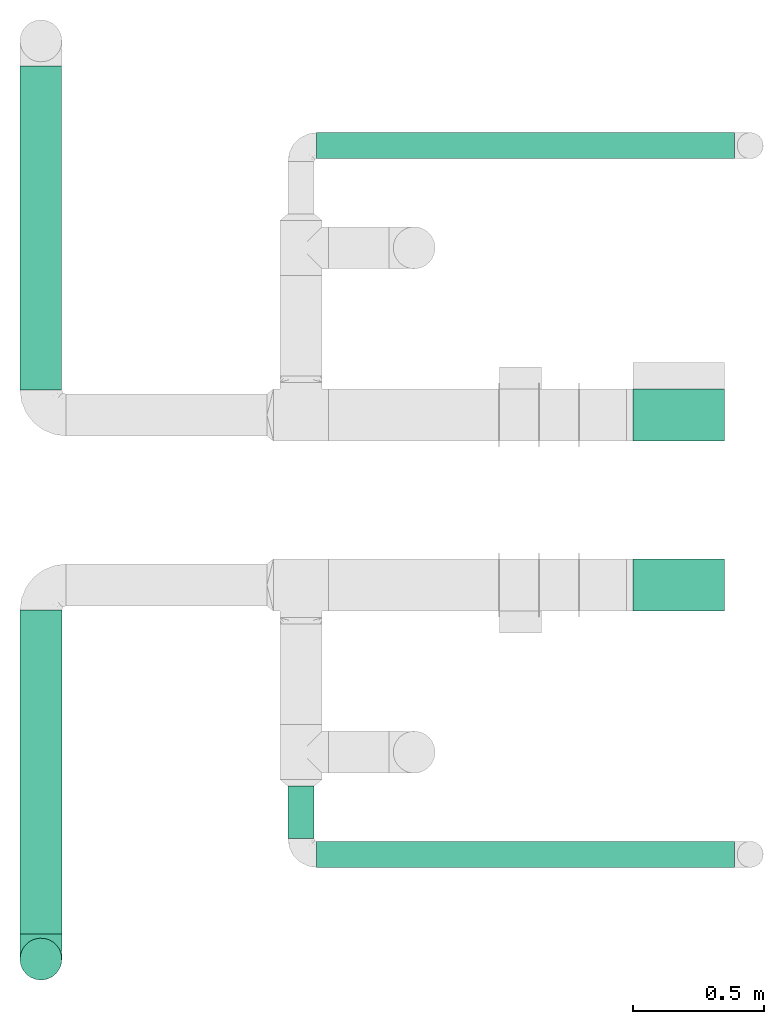
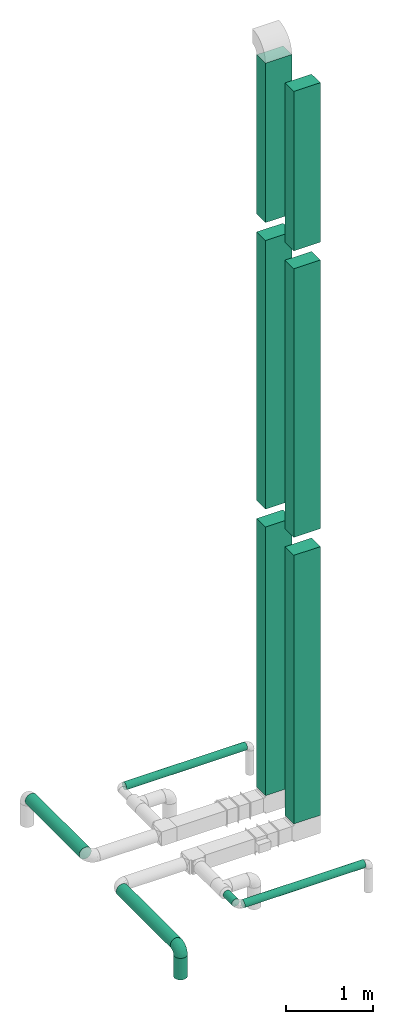
# One storey, part 1 of 12: 12 flow segments, 1 flow fitting.
"""IFC2X3 building model written with IfcOpenShell, lengths in millimetres."""

import ifcopenshell
import ifcopenshell.guid

model = None  # the IFC model being written
_history = None  # IfcOwnerHistory: only IFC2X3 demands one
_inside = {}  # id of a spatial element -> (the spatial element, [elements in it])
_under = {}  # id of a project, library or spatial element -> (it, [spatial elements below it])
_declared = {}  # id of a project -> (the project, [libraries it declares])
_typed = {}  # id of a type object -> (the type object, [elements of that type])
_made_of = {}  # id of a material, layer set ... -> (it, [elements and type objects made of it])


def new_model(schema):
    """Start an empty IFC model of exactly this schema.

    Asked for "IFC4X3", IfcOpenShell would pick the latest addendum, in which some entities
    have other attributes; the version numbers below select the first issue.
    IFC2X3 requires an IfcOwnerHistory on every rooted entity: one is made here for all.
    """
    global model, _history
    if schema == "IFC4X3":
        model = ifcopenshell.file(schema_version=(4, 3, 0, 0))
    else:
        model = ifcopenshell.file(schema=schema)
    _inside.clear()
    _under.clear()
    _declared.clear()
    _typed.clear()
    _made_of.clear()
    _history = None
    if model.schema == "IFC2X3":
        org = make("IfcOrganization", Name="unknown")
        user = make(
            "IfcPersonAndOrganization",
            ThePerson=make("IfcPerson", FamilyName="unknown"),
            TheOrganization=org,
        )
        app = make(
            "IfcApplication",
            ApplicationDeveloper=org,
            Version="unknown",
            ApplicationFullName="unknown",
            ApplicationIdentifier="unknown",
        )
        _history = make(
            "IfcOwnerHistory",
            OwningUser=user,
            OwningApplication=app,
            ChangeAction="ADDED",
            CreationDate=0,
        )
    return model


def make(cls, **values):
    """One entity of the class cls with the attributes given. An attribute that is None is left unset."""
    return model.create_entity(
        cls, **{name: value for name, value in values.items() if value is not None}
    )


def entity(cls, *values):
    """Any entity or typed value of the class cls, its attributes in the order of the schema. None: left unset."""
    e = model.create_entity(cls)
    for i, value in enumerate(values):
        if value is not None:
            e[i] = value
    return e


def rooted(cls, **values):
    """An entity with a GlobalId (a new one), such as an element, a storey or a relation."""
    return make(cls, GlobalId=ifcopenshell.guid.new(), OwnerHistory=_history, **values)


def si_unit(unit_type, name, prefix=None):
    """IfcSIUnit, for example si_unit("LENGTHUNIT", "METRE", prefix="MILLI")."""
    return make("IfcSIUnit", UnitType=unit_type, Prefix=prefix, Name=name)


def converted_unit(unit_type, name, factor, base, dimensions=None, offset=None):
    """IfcConversionBasedUnit, such as the inch: factor (a typed value) times the base unit."""
    return make(
        "IfcConversionBasedUnit"
        if offset is None
        else "IfcConversionBasedUnitWithOffset",
        ConversionOffset=offset,
        Dimensions=None
        if dimensions is None
        else entity("IfcDimensionalExponents", *dimensions),
        UnitType=unit_type,
        Name=name,
        ConversionFactor=make(
            "IfcMeasureWithUnit", ValueComponent=factor, UnitComponent=base
        ),
    )


def derived_unit(unit_type, elements):
    """IfcDerivedUnit: a product of units, each with its exponent."""
    return make(
        "IfcDerivedUnit",
        Elements=[
            make("IfcDerivedUnitElement", Unit=unit, Exponent=power)
            for unit, power in elements
        ],
        UnitType=unit_type,
    )


def assignment(units):
    """IfcUnitAssignment: the units of a project."""
    return None if units is None else make("IfcUnitAssignment", Units=units)


def point(xyz):
    """IfcCartesianPoint."""
    return None if xyz is None else make("IfcCartesianPoint", Coordinates=xyz)


def direction(xyz):
    """IfcDirection."""
    return None if xyz is None else make("IfcDirection", DirectionRatios=xyz)


def frame(location, z_axis=None, x_axis=None):
    """IfcAxis2Placement3D, a coordinate frame: its origin and axes. An axis left out is left unset."""
    return make(
        "IfcAxis2Placement3D",
        Location=point(location),
        Axis=direction(z_axis),
        RefDirection=direction(x_axis),
    )


def frame_2d(location, x_axis=None):
    """IfcAxis2Placement2D, a coordinate frame in the plane: its origin and x axis."""
    return make(
        "IfcAxis2Placement2D", Location=point(location), RefDirection=direction(x_axis)
    )


def origin():
    """The frame at (0, 0, 0) with its axes left unset."""
    return frame((0.0, 0.0, 0.0))


def origin_2d_with_axis():
    """The frame at (0, 0) in the plane with the x axis (1, 0) written out."""
    return frame_2d((0.0, 0.0), x_axis=(1.0, 0.0))


def place(relative_to, where):
    """IfcLocalPlacement: puts the frame where relative to a parent placement (None: the world)."""
    return make(
        "IfcLocalPlacement", PlacementRelTo=relative_to, RelativePlacement=where
    )


def context(
    kind, dimensions, precision=None, world=None, true_north=None, identifier=None
):
    """IfcGeometricRepresentationContext, for example the 3D "Model" context."""
    return make(
        "IfcGeometricRepresentationContext",
        ContextIdentifier=identifier,
        ContextType=kind,
        CoordinateSpaceDimension=dimensions,
        Precision=precision,
        WorldCoordinateSystem=world,
        TrueNorth=true_north,
    )


def subcontext(parent, identifier, kind, view, scale=None):
    """IfcGeometricRepresentationSubContext, for example "Body" below "Model"."""
    return make(
        "IfcGeometricRepresentationSubContext",
        ContextIdentifier=identifier,
        ContextType=kind,
        ParentContext=parent,
        TargetScale=scale,
        TargetView=view,
    )


def project(units=None, contexts=None):
    """IfcProject with its units and contexts."""
    return rooted(
        "IfcProject",
        Name="project",
        RepresentationContexts=contexts,
        UnitsInContext=assignment(units),
    )


def spatial(cls, under=None, at=None, **own):
    """A site, building, storey or space (cls), placed at a placement, below another one or the project."""
    s = rooted(cls, ObjectPlacement=at, **own)
    if under is not None:
        _under.setdefault(under.id(), (under, []))[1].append(s)
    return s


def profile(cls, at=None, kind="AREA", **sizes):
    """A parametric profile (cls). Its sizes go by their IFC names, for example OverallWidth=200.0."""
    return make(cls, ProfileType=kind, Position=at, **sizes)


def rectangle(**sizes):
    """IfcRectangleProfileDef."""
    return profile("IfcRectangleProfileDef", **sizes)


def circle(**sizes):
    """IfcCircleProfileDef."""
    return profile("IfcCircleProfileDef", **sizes)


def extrude(swept, where, along, depth):
    """IfcExtrudedAreaSolid: the profile swept, set in the frame where, extruded along a direction by depth."""
    return make(
        "IfcExtrudedAreaSolid",
        SweptArea=swept,
        Position=where,
        ExtrudedDirection=direction(along),
        Depth=depth,
    )


def faces_of(points, faces, orient=None, outer=None):
    """IfcFace entities. A face is a list of loops; a loop is a list of indices into points, from 0.

    orient and outer hold one flag for each loop. By default every Orientation is true, the
    first loop of a face is its IfcFaceOuterBound and the others are IfcFaceBound.
    """
    made = []
    for i, loops in enumerate(faces):
        bounds = []
        for j, loop in enumerate(loops):
            is_outer = j == 0 if outer is None else outer[i][j]
            bounds.append(
                make(
                    "IfcFaceOuterBound" if is_outer else "IfcFaceBound",
                    Bound=make("IfcPolyLoop", Polygon=[points[k] for k in loop]),
                    Orientation=True if orient is None else orient[i][j],
                )
            )
        made.append(make("IfcFace", Bounds=bounds))
    return made


def faceted_brep(points, faces, orient=None, outer=None, voids=None):
    """IfcFacetedBrep: a solid bounded by flat faces; with voids (closed shells), ...WithVoids."""
    shared = [point(p) for p in points]
    hull = make("IfcClosedShell", CfsFaces=faces_of(shared, faces, orient, outer))
    if voids is None:
        return make("IfcFacetedBrep", Outer=hull)
    return make(
        "IfcFacetedBrepWithVoids",
        Outer=hull,
        Voids=[
            make(cls, CfsFaces=faces_of(shared, fs, o, b)) for cls, fs, o, b in voids
        ],
    )


def shape(context_of_items, identifier, shape_type, items):
    """IfcShapeRepresentation: the items that make up one representation, for example the "Body"."""
    return make(
        "IfcShapeRepresentation",
        ContextOfItems=context_of_items,
        RepresentationIdentifier=identifier,
        RepresentationType=shape_type,
        Items=items,
    )


def source(mapping_origin, context_of_items, identifier, shape_type, items):
    """IfcRepresentationMap: a shape defined once, which mapped items show again and again."""
    return make(
        "IfcRepresentationMap",
        MappingOrigin=mapping_origin,
        MappedRepresentation=shape(context_of_items, identifier, shape_type, items),
    )


def transform(
    local_origin,
    x_axis=None,
    y_axis=None,
    z_axis=None,
    scale=None,
    scale2=None,
    scale3=None,
    uniform=True,
):
    """IfcCartesianTransformationOperator3D, or its non-uniform kind. x_axis, y_axis, z_axis: its Axis1, 2, 3."""
    if uniform:
        return make(
            "IfcCartesianTransformationOperator3D",
            Axis1=direction(x_axis),
            Axis2=direction(y_axis),
            LocalOrigin=point(local_origin),
            Scale=scale,
            Axis3=direction(z_axis),
        )
    return make(
        "IfcCartesianTransformationOperator3DnonUniform",
        Axis1=direction(x_axis),
        Axis2=direction(y_axis),
        LocalOrigin=point(local_origin),
        Scale=scale,
        Axis3=direction(z_axis),
        Scale2=scale2,
        Scale3=scale3,
    )


def mapped(mapping_source, mapping_target):
    """IfcMappedItem: shows the shape of a source again, moved by a transform."""
    return make(
        "IfcMappedItem", MappingSource=mapping_source, MappingTarget=mapping_target
    )


def made_of(thing, what):
    """Note that an element or type object is made of a material, layer set ...; save() writes the relation."""
    if what is not None:
        _made_of.setdefault(what.id(), (what, []))[1].append(thing)
    return thing


def type_object(cls, material=None, **own):
    """A type object (cls), such as IfcWallType, which elements share."""
    return made_of(rooted(cls, **own), material)


def type_shapes(of_type, sources):
    """Give a type object the sources (RepresentationMaps) that its elements show as mapped items."""
    of_type.RepresentationMaps = sources


def element(
    cls,
    number,
    at=None,
    inside=None,
    cuts=None,
    type_object=None,
    material=None,
    context=None,
    identifier="Body",
    shape_type=None,
    held_by="IfcProductDefinitionShape",
    body=None,
    shapes=None,
    **own,
):
    """One element of the class cls, such as IfcWall. Its Tag is "e" and its number.

    at: its placement. inside: the storey or other place that contains it. cuts: it is an
    opening in that element (IfcRelVoidsElement). A single representation is given by context,
    identifier, shape_type and body (its items); several are given by shapes. held_by: the class
    of the entity that holds the representations. save() writes the other relations.
    """
    e = rooted(cls, Tag="e%d" % number, ObjectPlacement=at, **own)
    if body is not None:
        shapes = [shape(context, identifier, shape_type, body)]
    if shapes is not None:
        e.Representation = make(held_by, Representations=shapes)
    if inside is not None:
        _inside.setdefault(inside.id(), (inside, []))[1].append(e)
    if cuts is not None:
        rooted(
            "IfcRelVoidsElement", RelatingBuildingElement=cuts, RelatedOpeningElement=e
        )
    if type_object is not None:
        _typed.setdefault(type_object.id(), (type_object, []))[1].append(e)
    return made_of(e, material)


def aggregate(whole, parts):
    """IfcRelAggregates: a whole, such as a stair, and the parts it consists of."""
    return rooted("IfcRelAggregates", RelatingObject=whole, RelatedObjects=parts)


def save(model, path):
    """Write the relations noted so far, then the file.

    IfcRelAggregates (storeys below a building ...), IfcRelContainedInSpatialStructure (elements
    in a storey), IfcRelDefinesByType, IfcRelAssociatesMaterial and IfcRelDeclares: one each for
    every whole, place, type object, material and project.
    """
    for whole, parts in _under.values():
        aggregate(whole, parts)
    for where, things in _inside.values():
        rooted(
            "IfcRelContainedInSpatialStructure",
            RelatedElements=things,
            RelatingStructure=where,
        )
    for kind, things in _typed.values():
        rooted("IfcRelDefinesByType", RelatedObjects=things, RelatingType=kind)
    for what, things in _made_of.values():
        rooted("IfcRelAssociatesMaterial", RelatedObjects=things, RelatingMaterial=what)
    for by, libraries in _declared.values():
        rooted("IfcRelDeclares", RelatingContext=by, RelatedDefinitions=libraries)
    model.write(path)


model = new_model("IFC2X3")

# Units and contexts
model_context = context("Model", 3, precision=0.01, world=origin(), true_north=direction((6.12303176911189e-17, 1.0)))
body_context = subcontext(model_context, "Body", "Model", "MODEL_VIEW")
ifc_project = project(units=[si_unit("LENGTHUNIT", "METRE", prefix="MILLI"), si_unit("AREAUNIT", "SQUARE_METRE"), si_unit("VOLUMEUNIT", "CUBIC_METRE"), converted_unit("PLANEANGLEUNIT", "DEGREE", entity("IfcRatioMeasure", 0.0174532925199433), si_unit("PLANEANGLEUNIT", "RADIAN"), dimensions=[0, 0, 0, 0, 0, 0, 0]), si_unit("MASSUNIT", "GRAM", prefix="KILO"), derived_unit("MASSDENSITYUNIT", [(si_unit("MASSUNIT", "GRAM", prefix="KILO"), 1), (si_unit("LENGTHUNIT", "METRE"), -3)]), si_unit("TIMEUNIT", "SECOND"), si_unit("FREQUENCYUNIT", "HERTZ"), si_unit("THERMODYNAMICTEMPERATUREUNIT", "DEGREE_CELSIUS"), derived_unit("THERMALTRANSMITTANCEUNIT", [(si_unit("MASSUNIT", "GRAM", prefix="KILO"), 1), (si_unit("THERMODYNAMICTEMPERATUREUNIT", "KELVIN"), -1), (si_unit("TIMEUNIT", "SECOND"), -3)]), derived_unit("VOLUMETRICFLOWRATEUNIT", [(si_unit("LENGTHUNIT", "METRE"), 3), (si_unit("TIMEUNIT", "SECOND"), -1)]), si_unit("ELECTRICCURRENTUNIT", "AMPERE"), si_unit("ELECTRICVOLTAGEUNIT", "VOLT"), si_unit("POWERUNIT", "WATT"), si_unit("FORCEUNIT", "NEWTON", prefix="KILO"), si_unit("ILLUMINANCEUNIT", "LUX"), si_unit("LUMINOUSFLUXUNIT", "LUMEN"), si_unit("LUMINOUSINTENSITYUNIT", "CANDELA"), derived_unit("USERDEFINED", [(si_unit("MASSUNIT", "GRAM", prefix="KILO"), -1), (si_unit("LENGTHUNIT", "METRE"), -2), (si_unit("TIMEUNIT", "SECOND"), 3), (si_unit("LUMINOUSFLUXUNIT", "LUMEN"), 1)]), derived_unit("LINEARVELOCITYUNIT", [(si_unit("LENGTHUNIT", "METRE"), 1), (si_unit("TIMEUNIT", "SECOND"), -1)]), si_unit("PRESSUREUNIT", "PASCAL"), derived_unit("USERDEFINED", [(si_unit("LENGTHUNIT", "METRE"), -2), (si_unit("MASSUNIT", "GRAM", prefix="KILO"), 1), (si_unit("TIMEUNIT", "SECOND"), -2)])], contexts=[model_context])

# Site, building, storey
site_placement = place(None, origin())
site = spatial("IfcSite", under=ifc_project, at=site_placement, CompositionType="ELEMENT")
building_placement = place(site_placement, origin())
building = spatial("IfcBuilding", under=site, at=building_placement, CompositionType="ELEMENT")
storey_placement = place(building_placement, frame((0.0, 0.0, 4000.0)))
storey = spatial("IfcBuildingStorey", under=building, at=storey_placement, Name="01 Level", CompositionType="ELEMENT", Elevation=4000.0)

# Flow segments
duct_segment_type_1 = type_object("IfcDuctSegmentType", Name="Round Duct:Air", PredefinedType="NOTDEFINED")
flow_segment_1_placement = place(storey_placement, frame((23245.9900708518, -70237.5308847274, 2948.40472776403)))
element("IfcFlowSegment", 1, at=flow_segment_1_placement, inside=storey, type_object=duct_segment_type_1, Name="Round Duct:Air", ObjectType="Round Duct:Air", context=body_context, shape_type="SweptSolid", body=[
    extrude(circle(Radius=50.0, at=origin_2d_with_axis()), frame((0.0, 51.5952722359132, 51.5952722359154), z_axis=(1.0, 0.0, 0.0), x_axis=(0.0, -1.0, 0.0)), (0.0, 0.0, 1.0), 1597.50000000001),
])
flow_segment_2_placement = place(storey_placement, frame((22110.1537099681, -70490.2395851399, 2918.40472776409)))
element("IfcFlowSegment", 2, at=flow_segment_2_placement, inside=storey, type_object=duct_segment_type_1, Name="Round Duct:Air", ObjectType="Round Duct:Air", context=body_context, shape_type="SweptSolid", body=[
    extrude(circle(Radius=80.0, at=origin_2d_with_axis()), frame((81.595272235915, 0.0, 81.5952722359161), z_axis=(0.0, 1.0, 0.0), x_axis=(1.0, 0.0, 0.0)), (0.0, 0.0, 1.0), 1238.20435582267),
])
flow_segment_3_placement = place(storey_placement, frame((22110.1537099681, -70667.8348573758, 2603.07847999999)))
element("IfcFlowSegment", 3, at=flow_segment_3_placement, inside=storey, type_object=duct_segment_type_1, Name="Round Duct:Air", ObjectType="Round Duct:Air", context=body_context, shape_type="SweptSolid", body=[
    extrude(circle(Radius=79.9999999999999, at=origin_2d_with_axis()), frame((81.595272235915, 81.595272235915, 0.0), z_axis=(0.0, 0.0, 1.0), x_axis=(-1.0, 0.0, 0.0)), (0.0, 0.0, 1.0), 300.921520000008),
])
flow_segment_4_placement = place(storey_placement, frame((23134.3947986159, -70125.9356124915, 2948.40472776403)))
element("IfcFlowSegment", 4, at=flow_segment_4_placement, inside=storey, type_object=duct_segment_type_1, Name="Round Duct:Air", ObjectType="Round Duct:Air", context=body_context, shape_type="SweptSolid", body=[
    extrude(circle(Radius=50.0, at=frame_2d((0.0, 1.08286712929839e-12), x_axis=(1.0, 0.0))), frame((51.5952722359175, 0.0, 51.5952722359175), z_axis=(0.0, 1.0, 0.0), x_axis=(1.0, 0.0, 0.0)), (0.0, 0.0, 1.0), 200.701380999497),
])
flow_segment_5_placement = place(storey_placement, frame((23245.9900708518, -67528.1388300243, 2948.40472776403)))
element("IfcFlowSegment", 5, at=flow_segment_5_placement, inside=storey, type_object=duct_segment_type_1, Name="Round Duct:Air", ObjectType="Round Duct:Air", context=body_context, shape_type="SweptSolid", body=[
    extrude(circle(Radius=50.0, at=origin_2d_with_axis()), frame((0.0, 51.5952722359305, 51.5952722359154), z_axis=(1.0, 0.0, 0.0), x_axis=(0.0, -1.0, 0.0)), (0.0, 0.0, 1.0), 1597.50000000001),
])
flow_segment_6_placement = place(storey_placement, frame((22110.1537099681, -68410.4439409626, 2918.40472776409)))
element("IfcFlowSegment", 6, at=flow_segment_6_placement, inside=storey, type_object=duct_segment_type_1, Name="Round Duct:Air", ObjectType="Round Duct:Air", context=body_context, shape_type="SweptSolid", body=[
    extrude(circle(Radius=80.0, at=frame_2d((-4.33146851719357e-12, 1.08286712929839e-12), x_axis=(1.0, 0.0))), frame((81.5952722359194, 0.0, 81.595272235915), z_axis=(0.0, 1.0, 0.0), x_axis=(-1.0, 0.0, 0.0)), (0.0, 0.0, 1.0), 1238.20435582267),
])
duct_segment_type_2 = type_object("IfcDuctSegmentType", Name="Rectangular Duct:Air", PredefinedType="NOTDEFINED")
flow_segment_7_placement = place(storey_placement, frame((24455.6615179763, -69256.0352293172, 11125.0)))
element("IfcFlowSegment", 7, at=flow_segment_7_placement, inside=storey, type_object=duct_segment_type_2, Name="Rectangular Duct:Air", ObjectType="Rectangular Duct:Air", context=body_context, shape_type="SweptSolid", body=[
    extrude(rectangle(XDim=349.999999999998, YDim=199.999999999998, at=frame_2d((0.0, -4.33431068813661e-12), x_axis=(1.0, 0.0))), frame((175.0, 100.0, 0.0)), (0.0, 0.0, 1.0), 2225.0),
])
flow_segment_8_placement = place(storey_placement, frame((24455.6615179764, -68606.4439409627, 11125.0)))
element("IfcFlowSegment", 8, at=flow_segment_8_placement, inside=storey, type_object=duct_segment_type_2, Name="Rectangular Duct:Air", ObjectType="Rectangular Duct:Air", context=body_context, shape_type="SweptSolid", body=[
    extrude(rectangle(XDim=200.000000000007, YDim=349.999999999998, at=frame_2d((-4.33431068813661e-12, 0.0), x_axis=(1.0, 0.0))), frame((175.0, 100.0, 0.0), z_axis=(0.0, 0.0, 1.0), x_axis=(0.0, -1.0, 0.0)), (0.0, 0.0, 1.0), 2225.0),
])
flow_segment_9_placement = place(storey_placement, frame((24455.6615179763, -68606.4439409627, 3125.0)))
element("IfcFlowSegment", 9, at=flow_segment_9_placement, inside=storey, type_object=duct_segment_type_2, Name="Rectangular Duct:Air", ObjectType="Rectangular Duct:Air", context=body_context, shape_type="SweptSolid", body=[
    extrude(rectangle(XDim=349.999999999998, YDim=199.999999999998, at=frame_2d((0.0, 1.29887212096946e-11), x_axis=(1.0, 0.0))), frame((175.0, 100.0, 0.0), z_axis=(0.0, 0.0, 1.0), x_axis=(-1.0, 0.0, 0.0)), (0.0, 0.0, 1.0), 3750.0),
])
flow_segment_10_placement = place(storey_placement, frame((24455.6615179764, -69256.0352293172, 3125.0)))
element("IfcFlowSegment", 10, at=flow_segment_10_placement, inside=storey, type_object=duct_segment_type_2, Name="Rectangular Duct:Air", ObjectType="Rectangular Duct:Air", context=body_context, shape_type="SweptSolid", body=[
    extrude(rectangle(XDim=200.000000000007, YDim=349.999999999998, at=frame_2d((-4.33431068813661e-12, 0.0), x_axis=(1.0, 0.0))), frame((175.0, 100.0, 0.0), z_axis=(0.0, 0.0, 1.0), x_axis=(0.0, 1.0, 0.0)), (0.0, 0.0, 1.0), 3750.0),
])
flow_segment_11_placement = place(storey_placement, frame((24455.6615179764, -68606.4439409627, 7125.0)))
element("IfcFlowSegment", 11, at=flow_segment_11_placement, inside=storey, type_object=duct_segment_type_2, Name="Rectangular Duct:Air", ObjectType="Rectangular Duct:Air", context=body_context, shape_type="SweptSolid", body=[
    extrude(rectangle(XDim=200.000000000007, YDim=349.999999999998, at=frame_2d((-4.33431068813661e-12, 0.0), x_axis=(1.0, 0.0))), frame((175.0, 100.0, 0.0), z_axis=(0.0, 0.0, 1.0), x_axis=(0.0, -1.0, 0.0)), (0.0, 0.0, 1.0), 3750.0),
])
flow_segment_12_placement = place(storey_placement, frame((24455.6615179764, -69256.0352293172, 7125.0)))
element("IfcFlowSegment", 12, at=flow_segment_12_placement, inside=storey, type_object=duct_segment_type_2, Name="Rectangular Duct:Air", ObjectType="Rectangular Duct:Air", context=body_context, shape_type="SweptSolid", body=[
    extrude(rectangle(XDim=200.000000000007, YDim=349.999999999998, at=frame_2d((-4.33431068813661e-12, 0.0), x_axis=(1.0, 0.0))), frame((175.0, 100.0, 0.0), z_axis=(0.0, 0.0, 1.0), x_axis=(0.0, 1.0, 0.0)), (0.0, 0.0, 1.0), 3750.0),
])

# Flow fitting
duct_fitting_type = type_object("IfcDuctFittingType", Name="Air_Elbow short_Circ", PredefinedType="NOTDEFINED")
shared_shape = source(origin(), body_context, "Body", "Brep", [
    faceted_brep([(-96.0, 40.0, -69.2820323027551), (-96.0, 20.7055236082018, -77.2740661031254), (-96.0, 0.0, -80.0), (-96.0, -20.7055236082015, -77.2740661031255), (-96.0, -40.0, -69.2820323027552), (-96.0, -56.5685424949237, -56.5685424949239), (-96.0, -69.282032302755, -40.0), (-96.0, -77.2740661031254, -20.7055236082019), (-96.0, -80.0, 0.0), (-96.0, -77.2740661031256, 20.7055236082014), (-96.0, -69.2820323027553, 40.0), (-96.0, -56.568542494924, 56.5685424949236), (-96.0, -40.0, 69.2820323027549), (-96.0, -20.705523608202, 77.2740661031254), (-96.0, 0.0, 80.0), (-96.0, 20.7055236082013, 77.2740661031256), (-96.0, 30.3527618041005, 73.2780492029404), (-96.0, 40.0, 69.2820323027553), (-96.0, 56.5685424949235, 56.5685424949241), (-96.0, 69.2820323027549, 40.0), (-96.0, 77.2740661031253, 20.7055236082021), (-96.0, 80.0, 0.0), (-96.0, 77.2740661031255, -20.7055236082016), (-96.0, 69.2820323027551, -40.0), (-96.0, 56.5685424949239, -56.5685424949238), (0.0, 96.0, -80.0), (-20.7055236082008, 96.0, -77.2740661031254), (-30.3527618041, 96.0, -73.2780492029402), (-40.0, 96.0, -69.2820323027551), (-56.5685424949229, 96.0, -56.5685424949238), (-69.2820323027542, 96.0, -40.0), (-77.2740661031245, 96.0, -20.7055236082016), (-80.0, 96.0, 0.0), (-77.2740661031244, 96.0, 20.7055236082021), (-69.2820323027539, 96.0, 40.0), (-56.5685424949226, 96.0, 56.5685424949241), (-40.0, 96.0, 69.2820323027553), (-20.7055236082004, 96.0, 77.2740661031256), (0.0, 96.0, 80.0), (20.7055236082029, 96.0, 77.2740661031254), (40.0, 96.0, 69.2820323027549), (56.5685424949249, 96.0, 56.5685424949236), (69.2820323027562, 96.0, 40.0), (77.2740661031265, 96.0, 20.7055236082014), (80.0, 96.0, 0.0), (77.2740661031264, 96.0, -20.7055236082019), (69.2820323027559, 96.0, -40.0), (56.5685424949246, 96.0, -56.5685424949239), (40.0, 96.0, -69.2820323027552), (20.7055236082025, 96.0, -77.2740661031255), (-69.6571465232348, 6.28172173912476, 79.9611058756859), (-55.1380888291464, -64.4450584799279, 39.5029426177976), (-78.4902527850466, -65.2482264041437, 44.9229732355936), (-66.7862289407348, -74.1387210661139, 22.9795507758541), (-79.9123689128389, 22.4151301859584, 77.2816866630488), (-75.1250134759213, 46.3506195730757, 68.0011973810265), (-46.2820694578435, -43.7397705581167, 60.5188244193914), (-62.9760666105318, -34.5362195419601, 70.0448030595901), (-67.1316735243184, -51.7530432423058, 58.5204707533666), (-50.4478480619551, -74.0029454268759, 0.0), (-76.2276812833835, -77.3969248578635, 0.0), (-27.189372084162, 68.980536479128, 76.8941402015288), (-6.30632028234235, 70.6421404093778, 79.9513108199466), (-47.7584488981354, -13.6212410427434, 76.3881123659885), (-29.8609237116382, -28.9682345099716, 65.8760199345924), (57.6005967886466, 33.4719572927763, 39.0176496769077), (51.7530435574228, 67.1316742002235, 58.5204705859065), (43.7397637815864, 46.2820598522933, 60.518827155348), (-74.2591571701267, -14.3645886695287, 78.2829835259588), (28.4507934888335, -28.4507934888321, 0.0), (23.3846344985257, -27.9066135199674, 24.7887114209846), (7.8513563843086, -42.4938374080907, 21.3232874317503), (-84.190871651952, 70.905997349447, 41.7100461919055), (24.7272484782103, -2.06889411058577, 53.4325037134459), (-0.0180155578363953, -25.9284255475521, 53.836744023285), (10.21505333872, -32.0754161621096, 38.020212353501), (-64.5619855594544, 27.52018553659, 77.2892967298799), (-41.7574890626937, 15.123136403511, 79.988056483004), (-24.5336756868846, -60.9669573051438, 23.5003835585885), (-29.2239240309769, -65.2117082464685, 0.0), (-8.0, -56.420471066061, 0.0), (-16.4008295437786, 51.3122057461681, 79.8609584412684), (-83.0529092063249, 83.0529092103045, 19.0855009657076), (-84.6862915010143, 84.6862915010152, 0.0), (-82.4185651555764, 62.2587017800419, 53.3339952483838), (-46.3022193149449, 75.902750025661, 67.8445262622594), (-9.5260688639158, -47.7232209131232, 35.4187162694583), (74.1387213421635, 66.7862279048973, 22.9795492840646), (14.3645870599314, 74.259154996167, 78.2829837700474), (34.536215572589, 62.976064096567, 70.0448048426748), (65.2482273833467, 78.4902510979302, 44.9229715327465), (-12.3935655196116, 25.4017250572252, 78.8652642576962), (-25.6317751341749, 1.2640655514879, 76.9124052095498), (69.8186739706361, 42.5625104806759, 16.7980672722629), (64.4450597015273, 55.1380839274934, 39.5029384026545), (60.9669574479924, 24.5336725945725, 23.5003789659965), (77.3969247188647, 76.2276802275763, 0.0), (74.002945426877, 50.4478480619565, 0.0), (-66.5995156060253, 66.5995146556305, 58.6370817132137), (-52.4774893100348, 53.0631556360015, 72.0041598972686), (-76.4857465466113, 78.9385356944492, 38.5867538667356), (-62.2587016209511, 82.4185645906685, 53.3339956492136), (28.9682276847195, 29.8609133580269, 65.8760207540895), (13.6212369177471, 47.7584433090926, 76.3881128402526), (-6.49930484510329, -53.7890406240985, 15.4645725223014), (-33.731289034344, 40.0214486160993, 79.0537019298314), (46.1336936566893, 26.2441492635858, 50.151541479116), (42.4356322774479, -10.225396744416, 0.0), (56.4204710660622, 8.0, 0.0), (50.0005984633279, 1.26038287501495, 17.5763945268078), (-45.4536887619888, -68.8356359385787, 23.6914879663761), (-33.3493864711472, -57.4572215948989, 39.1720709545353), (35.9683398342664, -11.0724559744972, 30.5391080332169), (-26.2441652621668, -46.1336984778153, 50.1515448602929), (36.6749123583047, -17.5982116941791, 14.5644188861001), (65.2117082464696, 29.2239240309784, 0.0), (49.5968730216335, 12.1440064858134, 34.8325942562253), (-47.1533280807863, 29.0746114834461, 78.9127210009486), (-0.981722938535007, 51.3162880079176, 79.4920802366619), (12.4951682569875, 20.0804783439543, 71.2292489374933), (-1.95170750213435, 1.95169859379814, 70.9272590604952), (13.0725391330592, 1.13338064801589, 63.5790506070627), (-1.93327092594732, -13.4823821925323, 63.7412032706882), (-18.9298205951927, -13.0048872663631, 70.6672094580024), (10.2253967444173, -42.4356322774466, 0.0), (-68.9805369123341, 27.1893702897943, -76.8941406355589), (-22.4151342180024, 79.9123577737124, -77.2816862456941), (-27.5201921618733, 64.5619784506715, -77.2892959136582), (-46.3506180288022, 75.1250185023919, -68.0011970559212), (-74.2591561090454, -14.364589592643, -78.2829832920378), (-42.5625109127564, -69.8186736490614, -16.7980693145318), (-66.78622820047, -74.1387209331735, -22.9795507950237), (-70.6421421271429, 6.30631801763141, -79.9513108797024), (-25.401718902627, 12.3935649209934, -78.8652635038296), (-15.1231475192353, 41.7574898106582, -79.9880566497423), (-1.2640784754681, 25.6317655571971, -76.9124065444174), (-78.9385361639639, 76.4857467527193, -38.5867530236755), (-66.5995166501766, 66.5995137008527, -58.6370816545605), (-82.4185656924104, 62.258701559575, -53.3339952529289), (60.9669567069012, 24.5336743104721, -23.5003834743896), (53.7890400497189, 6.49930371043273, -15.4645720709197), (-55.1380878256228, -64.4450583029017, -39.5029424837467), (-24.5336751436549, -60.9669572920351, -23.5003828649414), (-29.8609212227281, -28.9682353164184, -65.8760186412515), (-26.2441631797834, -46.1336980827234, -50.1515441608816), (-46.2820677406335, -43.7397707662098, -60.5188237522514), (74.1387206827049, 66.7862275406284, -22.9795512458422), (-40.0214489824224, 33.7312845774564, -79.0537024061946), (-78.4902524468744, -65.2482264004152, -44.9229731872606), (-75.902751427461, 46.3022186029078, -67.8445263463497), (-70.9059970555813, 84.1908706304995, -41.7100473389448), (-67.1316724627346, -51.7530434014037, -58.5204704180807), (-62.9760652707231, -34.536220162299, -70.044802546446), (-33.4719630839568, -57.6005950429912, -39.0176564793206), (-51.3122062597491, 16.4008248291117, -79.8609586691244), (-6.28171714934502, 69.65712797409, -79.9611061760713), (51.7530427306645, 67.1316703492073, -58.5204706539109), (-83.0529092397056, 83.0529091932979, -19.0855009185769), (68.8356349913375, 45.45368838847, -23.6914905340598), (-62.258701383479, 82.4185638376438, -53.3339962098694), (34.53621889603, 62.9760621802168, -70.0448028055675), (-1.26038544288408, -50.0005998980998, -17.5763953891677), (13.6212385978137, 47.75844096294, -76.3881120677864), (14.3645887716112, 74.2591526334116, -78.2829833202131), (65.2482261461557, 78.4902526871683, -44.9229735979605), (2.068884460932, -24.7272580800759, -53.4325021883878), (25.9284207554091, 0.0180077987247146, -53.8367428868672), (32.0754071702863, -10.2150656939878, -38.0202105656364), (47.723215348146, 9.52606271707191, -35.4187195087105), (27.9066094773716, -23.3846413342612, -24.7887058003424), (42.4938359077841, -7.8513587520169, -21.3232866357369), (28.9682309044935, 29.8609168472814, -65.8760199178674), (64.4450577206072, 55.1380878066959, -39.5029434692504), (-53.063150048133, 52.4774843719861, -72.0041634993662), (43.7397687897612, 46.2820667462245, -60.5188250739327), (-47.7584463040963, -13.6212426330217, -76.3881115880261), (57.4572201066452, 33.3493827160302, -39.1720708806551), (11.0724494499294, -35.9683446288498, -30.5391089716619), (46.1336964749623, 26.2441642243134, -50.1515465265606), (17.5982028158329, -36.6749194460897, -14.5644209948051), (-12.1440097531109, -49.5968729214507, -34.8325978072281), (-29.0746218055845, 47.1533256390974, -78.912719851915), (-51.3162911259858, 0.981717610547608, -79.4920798409907), (-20.0804667507281, -12.4951842966219, -71.2292388196267), (-1.95170139871169, 1.95169735730944, -70.9272563527003), (-1.13337124471279, -13.072540998247, -63.5790448193562), (13.4823844636247, 1.93327501577089, -63.7412039856557), (13.0048800657406, 18.9298191902065, -70.6672121474654)], [[[0, 1, 2, 3, 4, 5, 6, 7, 8, 9, 10, 11, 12, 13, 14, 15, 16, 17, 18, 19, 20, 21, 22, 23, 24]], [[25, 26, 27, 28, 29, 30, 31, 32, 33, 34, 35, 36, 37, 38, 39, 40, 41, 42, 43, 44, 45, 46, 47, 48, 49]], [[15, 14, 50]], [[51, 52, 53]], [[54, 55, 17]], [[56, 57, 58]], [[59, 53, 60]], [[37, 61, 62]], [[63, 57, 64]], [[65, 66, 67]], [[52, 11, 10]], [[58, 57, 12]], [[68, 14, 13]], [[69, 70, 71]], [[72, 20, 19]], [[57, 63, 68]], [[73, 74, 75]], [[76, 50, 77]], [[13, 12, 57]], [[17, 55, 18]], [[17, 16, 15, 54]], [[78, 79, 80]], [[81, 62, 61]], [[21, 82, 83]], [[57, 56, 64]], [[21, 20, 82]], [[84, 72, 19]], [[12, 11, 58]], [[19, 18, 84]], [[36, 85, 61]], [[75, 74, 86]], [[53, 9, 60]], [[53, 10, 9]], [[42, 87, 43]], [[66, 41, 40]], [[88, 89, 39]], [[42, 41, 90]], [[40, 39, 89]], [[91, 77, 92]], [[87, 42, 90]], [[93, 94, 95]], [[89, 66, 40]], [[87, 96, 43]], [[36, 35, 85]], [[93, 97, 87]], [[85, 98, 99]], [[33, 100, 34]], [[82, 100, 33]], [[100, 98, 101]], [[102, 89, 103]], [[83, 82, 32]], [[78, 80, 104]], [[36, 61, 37]], [[61, 85, 99]], [[105, 77, 91]], [[102, 106, 67]], [[35, 34, 101]], [[37, 62, 38]], [[107, 108, 109]], [[110, 51, 53]], [[88, 39, 38]], [[78, 110, 79]], [[59, 79, 110]], [[51, 110, 111]], [[75, 70, 112]], [[111, 86, 113]], [[107, 114, 69]], [[106, 102, 73]], [[115, 93, 95]], [[62, 88, 38]], [[115, 95, 108]], [[116, 95, 65]], [[95, 116, 109]], [[68, 50, 14]], [[76, 77, 117]], [[76, 117, 99]], [[84, 55, 98]], [[101, 85, 35]], [[98, 55, 99]], [[81, 61, 105]], [[62, 118, 88]], [[67, 66, 89]], [[90, 66, 94]], [[52, 58, 11]], [[58, 51, 111]], [[50, 63, 77]], [[92, 77, 63]], [[119, 91, 120]], [[81, 118, 62]], [[120, 121, 119]], [[73, 112, 116]], [[120, 122, 121]], [[123, 122, 120]], [[74, 64, 113]], [[92, 123, 120]], [[74, 113, 86]], [[73, 121, 122]], [[76, 99, 55]], [[61, 99, 105]], [[9, 8, 60]], [[96, 87, 97]], [[96, 44, 43]], [[89, 88, 103]], [[57, 68, 13]], [[50, 68, 63]], [[100, 101, 34]], [[85, 101, 98]], [[55, 84, 18]], [[72, 98, 100]], [[105, 91, 81]], [[118, 91, 103]], [[91, 118, 81]], [[88, 118, 103]], [[98, 72, 84]], [[72, 100, 82]], [[82, 20, 72]], [[32, 82, 33]], [[53, 52, 10]], [[58, 52, 51]], [[66, 90, 41]], [[87, 90, 94]], [[76, 55, 54]], [[15, 50, 54]], [[50, 76, 54]], [[110, 53, 59]], [[111, 110, 78]], [[78, 104, 86]], [[111, 113, 56]], [[78, 86, 111]], [[86, 71, 75]], [[70, 75, 71]], [[73, 75, 112]], [[104, 124, 71]], [[95, 109, 108]], [[70, 114, 112]], [[94, 65, 95]], [[114, 109, 112]], [[69, 114, 70]], [[109, 114, 107]], [[73, 116, 106]], [[112, 109, 116]], [[66, 65, 94]], [[106, 116, 65]], [[97, 93, 115]], [[86, 104, 71]], [[124, 104, 80]], [[124, 69, 71]], [[94, 93, 87]], [[102, 67, 89]], [[65, 67, 106]], [[111, 56, 58]], [[64, 56, 113]], [[77, 105, 117]], [[99, 117, 105]], [[123, 63, 64]], [[91, 92, 120]], [[63, 123, 92]], [[122, 64, 74]], [[64, 122, 123]], [[73, 122, 74]], [[73, 102, 121]], [[119, 121, 102]], [[102, 103, 119]], [[91, 119, 103]], [[0, 125, 1]], [[126, 127, 128]], [[3, 2, 129]], [[130, 59, 131]], [[1, 132, 2]], [[133, 134, 135]], [[136, 137, 138]], [[139, 108, 140]], [[23, 138, 24]], [[130, 141, 142]], [[23, 22, 136]], [[143, 144, 145]], [[146, 46, 45]], [[147, 134, 133]], [[131, 6, 148]], [[0, 24, 149]], [[131, 60, 7]], [[150, 31, 30]], [[151, 4, 152]], [[153, 151, 145]], [[5, 4, 151]], [[4, 3, 152]], [[154, 132, 125]], [[5, 148, 6]], [[26, 25, 155]], [[3, 129, 152]], [[6, 131, 7]], [[48, 47, 156]], [[21, 83, 157]], [[139, 158, 115]], [[32, 31, 157]], [[157, 136, 22]], [[30, 159, 150]], [[49, 48, 160]], [[124, 80, 161]], [[29, 159, 30]], [[28, 27, 26, 126]], [[149, 125, 0]], [[127, 155, 134]], [[160, 162, 163]], [[164, 47, 46]], [[29, 28, 128]], [[165, 166, 167]], [[49, 163, 25]], [[168, 167, 166]], [[1, 125, 132]], [[139, 115, 108]], [[69, 169, 170]], [[162, 160, 171]], [[156, 160, 48]], [[172, 164, 146]], [[149, 137, 173]], [[146, 96, 97]], [[160, 174, 171]], [[143, 152, 175]], [[156, 174, 160]], [[125, 149, 173]], [[126, 128, 28]], [[97, 115, 158]], [[157, 22, 21]], [[158, 172, 146]], [[146, 45, 96]], [[172, 158, 176]], [[167, 169, 177]], [[176, 168, 178]], [[124, 179, 69]], [[144, 143, 165]], [[79, 130, 142]], [[45, 44, 96]], [[79, 142, 80]], [[180, 142, 153]], [[142, 180, 161]], [[163, 155, 25]], [[181, 134, 147]], [[127, 181, 173]], [[159, 128, 137]], [[138, 149, 24]], [[137, 128, 173]], [[154, 125, 147]], [[132, 182, 129]], [[145, 151, 152]], [[148, 151, 141]], [[164, 156, 47]], [[156, 172, 176]], [[155, 162, 134]], [[135, 134, 162]], [[183, 133, 184]], [[154, 182, 132]], [[184, 185, 183]], [[165, 177, 180]], [[184, 186, 185]], [[187, 186, 184]], [[166, 171, 178]], [[135, 187, 184]], [[166, 178, 168]], [[165, 185, 186]], [[127, 173, 128]], [[125, 173, 147]], [[60, 131, 59]], [[60, 8, 7]], [[132, 129, 2]], [[152, 129, 175]], [[160, 163, 49]], [[155, 163, 162]], [[136, 138, 23]], [[149, 138, 137]], [[128, 159, 29]], [[150, 137, 136]], [[147, 133, 154]], [[182, 133, 175]], [[133, 182, 154]], [[129, 182, 175]], [[137, 150, 159]], [[150, 136, 157]], [[32, 157, 83]], [[157, 31, 150]], [[146, 164, 46]], [[156, 164, 172]], [[151, 148, 5]], [[131, 148, 141]], [[127, 126, 155]], [[26, 155, 126]], [[158, 146, 97]], [[176, 158, 139]], [[139, 140, 168]], [[176, 178, 174]], [[139, 168, 176]], [[168, 170, 167]], [[169, 167, 170]], [[165, 167, 177]], [[140, 107, 170]], [[142, 161, 80]], [[169, 179, 177]], [[141, 153, 142]], [[179, 161, 177]], [[69, 179, 169]], [[161, 179, 124]], [[165, 180, 144]], [[177, 161, 180]], [[151, 153, 141]], [[144, 180, 153]], [[59, 130, 79]], [[168, 140, 170]], [[107, 140, 108]], [[107, 69, 170]], [[141, 130, 131]], [[143, 145, 152]], [[153, 145, 144]], [[176, 174, 156]], [[171, 174, 178]], [[173, 181, 147]], [[127, 134, 181]], [[187, 162, 171]], [[133, 135, 184]], [[162, 187, 135]], [[186, 171, 166]], [[171, 186, 187]], [[165, 186, 166]], [[165, 143, 185]], [[183, 185, 143]], [[143, 175, 183]], [[133, 183, 175]]]),
])
type_shapes(duct_fitting_type, [shared_shape])
flow_fitting_placement = place(storey_placement, frame((22191.748982204, -70586.2395851399, 3000.0), z_axis=(-1.0, 0.0, 0.0), x_axis=(0.0, 0.0, 1.0)))
element("IfcFlowFitting", 13, at=flow_fitting_placement, inside=storey, type_object=duct_fitting_type, Name="elbow_short_001:Air_Elbow short_Circ", ObjectType="elbow_short_001:Air_Elbow short_Circ", context=body_context, shape_type="MappedRepresentation", body=[
    mapped(shared_shape, transform((0.0, 0.0, 0.0), scale=1.0)),
])

save(model, "model.ifc")
